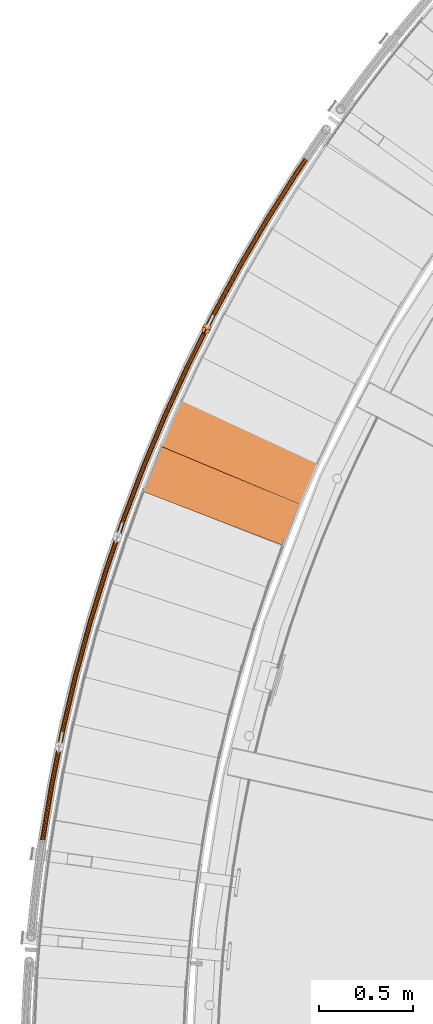
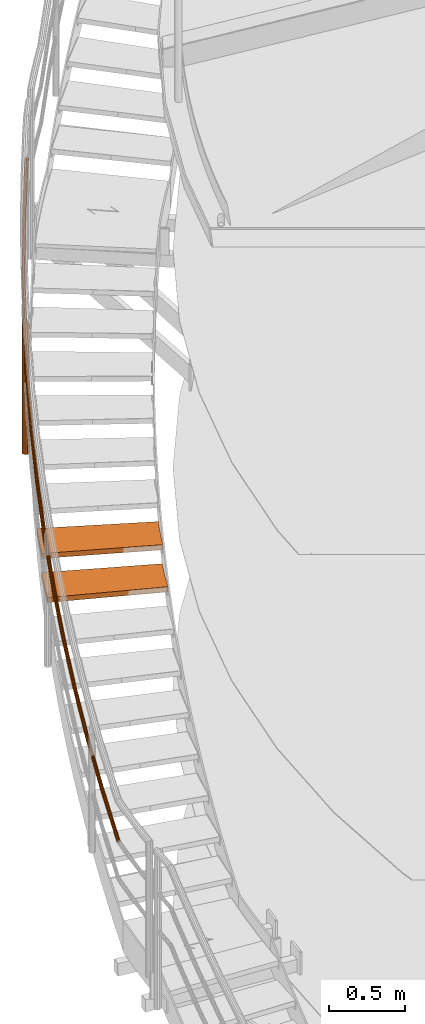
# One storey, part 28 of 126: 4 proxies.
"""IFC2X3 building model written with IfcOpenShell, lengths in millimetres."""

from ifc_helpers import new_model, si_unit, origin, origin_with_axes, place, context, project, spatial, faceted_brep, material, element, save


model = new_model("IFC2X3")

# Units and contexts
context_of_model_1 = context(None, 3, precision=0.1, world=origin())
context_of_model_2 = context(None, 3, precision=0.1, world=origin())
ifc_project = project(units=[si_unit("LENGTHUNIT", "METRE", prefix="MILLI"), si_unit("AREAUNIT", "SQUARE_METRE", prefix="CENTI"), si_unit("VOLUMEUNIT", "CUBIC_METRE", prefix="CENTI"), si_unit("MASSUNIT", "GRAM", prefix="KILO")], contexts=[context_of_model_1, context_of_model_2])

# Site, building, storey
site_placement = place(None, origin_with_axes())
site = spatial("IfcSite", under=ifc_project, at=site_placement, CompositionType="ELEMENT")
building_placement = place(site_placement, origin_with_axes())
building = spatial("IfcBuilding", under=site, at=building_placement, CompositionType="ELEMENT")
storey_placement = place(building_placement, origin_with_axes())
storey = spatial("IfcBuildingStorey", under=building, at=storey_placement, CompositionType="ELEMENT")

# Proxies
ifc_material_1 = material(Name="HOLZ")
proxy_1_placement = place(storey_placement, origin_with_axes())
element("IfcBuildingElementProxy", 1, at=proxy_1_placement, inside=storey, material=ifc_material_1, context=context_of_model_2, shape_type="Brep", body=[
    faceted_brep([(-118.3922, 11432.825, 6928.25), (-128.5897, 11408.558, 6928.25), (-138.7147, 11384.26, 6928.25), (-148.7672, 11359.932, 6928.25), (-158.7469, 11335.574, 6928.25), (-168.6539, 11311.186, 6928.25), (-178.4881, 11286.769, 6928.25), (-188.2493, 11262.323, 6928.25), (-197.9374, 11237.848, 6928.25), (-207.5525, 11213.344, 6928.25), (-217.0944, 11188.811, 6928.25), (-226.5629, 11164.25, 6928.25), (520.3181, 10877.599, 6928.25), (529.8906, 10902.417, 6928.25), (539.5453, 10927.204, 6928.25), (549.2822, 10951.958, 6928.25), (559.1012, 10976.679, 6928.25), (569.0022, 11001.368, 6928.25), (578.985, 11026.025, 6928.25), (589.0496, 11050.647, 6928.25), (599.1959, 11075.237, 6928.25), (609.4236, 11099.792, 6928.25), (619.7328, 11124.313, 6928.25), (-118.3922, 11432.825, 6888.25), (619.7328, 11124.313, 6888.25), (609.4236, 11099.792, 6888.25), (599.1959, 11075.237, 6888.25), (589.0496, 11050.647, 6888.25), (578.985, 11026.025, 6888.25), (569.0022, 11001.368, 6888.25), (559.1012, 10976.679, 6888.25), (549.2822, 10951.958, 6888.25), (539.5453, 10927.204, 6888.25), (529.8906, 10902.417, 6888.25), (520.3181, 10877.599, 6888.25), (-226.5629, 11164.25, 6888.25), (-217.0944, 11188.811, 6888.25), (-207.5525, 11213.344, 6888.25), (-197.9374, 11237.848, 6888.25), (-188.2493, 11262.323, 6888.25), (-178.4881, 11286.769, 6888.25), (-168.6539, 11311.186, 6888.25), (-158.7469, 11335.574, 6888.25), (-148.7672, 11359.932, 6888.25), (-138.7147, 11384.26, 6888.25), (-128.5897, 11408.558, 6888.25)], [[[0, 1, 2, 3, 4, 5, 6, 7, 8, 9, 10, 11, 12, 13, 14, 15, 16, 17, 18, 19, 20, 21, 22]], [[23, 24, 25, 26, 27, 28, 29, 30, 31, 32, 33, 34, 35, 36, 37, 38, 39, 40, 41, 42, 43, 44, 45]], [[0, 23, 45, 1]], [[1, 45, 44, 2]], [[2, 44, 43, 3]], [[3, 43, 42, 4]], [[4, 42, 41, 5]], [[5, 41, 40, 6]], [[6, 40, 39, 7]], [[7, 39, 38, 8]], [[8, 38, 37, 9]], [[9, 37, 36, 10]], [[10, 36, 35, 11]], [[11, 35, 34, 12]], [[12, 34, 33, 13]], [[13, 33, 32, 14]], [[14, 32, 31, 15]], [[15, 31, 30, 16]], [[16, 30, 29, 17]], [[17, 29, 28, 18]], [[18, 28, 27, 19]], [[19, 27, 26, 20]], [[20, 26, 25, 21]], [[21, 25, 24, 22]], [[22, 24, 23, 0]]]),
])
proxy_2_placement = place(storey_placement, origin_with_axes())
element("IfcBuildingElementProxy", 2, at=proxy_2_placement, inside=storey, material=ifc_material_1, context=context_of_model_2, shape_type="Brep", body=[
    faceted_brep([(-13.9794, 11670.441, 7101.4563), (-24.8868, 11646.484, 7101.4563), (-35.7226, 11622.495, 7101.4563), (-46.4867, 11598.473, 7101.4563), (-57.1791, 11574.419, 7101.4563), (-67.7996, 11550.334, 7101.4563), (-78.3482, 11526.217, 7101.4563), (-88.8247, 11502.069, 7101.4563), (-99.2291, 11477.889, 7101.4563), (-109.5612, 11453.679, 7101.4563), (-119.821, 11429.437, 7101.4563), (-130.0084, 11405.165, 7101.4563), (608.1119, 11096.656, 7101.4563), (618.4107, 11121.181, 7101.4563), (628.7908, 11145.673, 7101.4563), (639.2521, 11170.129, 7101.4563), (649.7945, 11194.552, 7101.4563), (660.4179, 11218.939, 7101.4563), (671.1221, 11243.29, 7101.4563), (681.9071, 11267.606, 7101.4563), (692.7726, 11291.886, 7101.4563), (703.7187, 11316.13, 7101.4563), (714.7452, 11340.337, 7101.4563), (-13.9794, 11670.441, 7061.4563), (714.7452, 11340.337, 7061.4563), (703.7187, 11316.13, 7061.4563), (692.7726, 11291.886, 7061.4563), (681.9071, 11267.606, 7061.4563), (671.1221, 11243.29, 7061.4563), (660.4179, 11218.939, 7061.4563), (649.7945, 11194.552, 7061.4563), (639.2521, 11170.129, 7061.4563), (628.7908, 11145.673, 7061.4563), (618.4107, 11121.181, 7061.4563), (608.1119, 11096.656, 7061.4563), (-130.0084, 11405.165, 7061.4563), (-119.821, 11429.437, 7061.4563), (-109.5612, 11453.679, 7061.4563), (-99.2291, 11477.889, 7061.4563), (-88.8247, 11502.069, 7061.4563), (-78.3482, 11526.217, 7061.4563), (-67.7996, 11550.334, 7061.4563), (-57.1791, 11574.419, 7061.4563), (-46.4867, 11598.473, 7061.4563), (-35.7226, 11622.495, 7061.4563), (-24.8868, 11646.484, 7061.4563)], [[[0, 1, 2, 3, 4, 5, 6, 7, 8, 9, 10, 11, 12, 13, 14, 15, 16, 17, 18, 19, 20, 21, 22]], [[23, 24, 25, 26, 27, 28, 29, 30, 31, 32, 33, 34, 35, 36, 37, 38, 39, 40, 41, 42, 43, 44, 45]], [[0, 23, 45, 1]], [[1, 45, 44, 2]], [[2, 44, 43, 3]], [[3, 43, 42, 4]], [[4, 42, 41, 5]], [[5, 41, 40, 6]], [[6, 40, 39, 7]], [[7, 39, 38, 8]], [[8, 38, 37, 9]], [[9, 37, 36, 10]], [[10, 36, 35, 11]], [[11, 35, 34, 12]], [[12, 34, 33, 13]], [[13, 33, 32, 14]], [[14, 32, 31, 15]], [[15, 31, 30, 16]], [[16, 30, 29, 17]], [[17, 29, 28, 18]], [[18, 28, 27, 19]], [[19, 27, 26, 20]], [[20, 26, 25, 21]], [[21, 25, 24, 22]], [[22, 24, 23, 0]]]),
])
ifc_material_2 = material(Name="S235JRG2")
proxy_3_placement = place(storey_placement, origin_with_axes())
element("IfcBuildingElementProxy", 3, at=proxy_3_placement, inside=storey, material=ifc_material_2, context=context_of_model_2, shape_type="Brep", body=[
    faceted_brep([(-762.4523, 9308.8607, 6318.9317), (-768.9726, 9310.8484, 6317.5115), (-770.9614, 9295.8563, 6306.8524), (-764.3214, 9294.7711, 6308.9142), (-773.4726, 9314.362, 6313.5264), (-775.6719, 9297.7832, 6301.7392), (-774.7467, 9318.4601, 6308.0441), (-777.1909, 9300.0356, 6294.9446), (-772.4534, 9322.0447, 6302.5336), (-775.1113, 9302.0098, 6288.2892), (-767.2073, 9324.1551, 6298.4715), (-769.9902, 9303.1769, 6283.5564), (-760.414, 9324.226, 6296.9461), (-763.2001, 9303.2242, 6282.0143), (-753.8938, 9322.2383, 6298.3662), (-756.5601, 9302.139, 6284.076), (-749.3937, 9318.7246, 6302.3513), (-751.8496, 9300.2121, 6289.1893), (-748.1196, 9314.6265, 6307.8336), (-750.3306, 9297.9598, 6295.9839), (-750.4129, 9311.042, 6313.3441), (-752.4103, 9295.9855, 6302.6392), (-755.659, 9308.9316, 6317.4063), (-757.5313, 9294.8184, 6307.372), (-762.3008, 9310.0031, 6317.297), (-756.5176, 9310.0634, 6315.9985), (-758.4576, 9295.4398, 6305.6014), (-764.2381, 9295.3996, 6306.9142), (-752.0516, 9311.8601, 6312.5404), (-754.0981, 9296.4334, 6301.5723), (-750.0993, 9314.9115, 6307.8493), (-752.3277, 9298.1141, 6295.9066), (-751.184, 9318.4003, 6303.1822), (-753.6207, 9300.0315, 6290.1223), (-755.0149, 9321.3914, 6299.7897), (-757.6308, 9301.6719, 6285.7695), (-760.5655, 9323.0836, 6298.5807), (-763.2834, 9302.5958, 6284.0143), (-766.3487, 9323.0232, 6299.8793), (-769.0639, 9302.5555, 6285.3271), (-770.8147, 9321.2266, 6303.3374), (-773.4234, 9301.5619, 6289.3561), (-772.767, 9318.1751, 6308.0285), (-775.1938, 9299.8812, 6295.0219), (-771.6824, 9314.6864, 6312.6956), (-773.9008, 9297.9638, 6300.8061), (-767.8515, 9311.6952, 6316.0881), (-769.8907, 9296.3234, 6305.159), (-714.2788, 9599.5063, 6526.5784), (-720.7294, 9601.7096, 6525.1583), (-725.1102, 9605.3709, 6521.1731), (-726.2473, 9609.5091, 6515.6908), (-723.8362, 9613.0154, 6510.1803), (-718.5228, 9614.9503, 6506.1182), (-711.7309, 9614.7953, 6504.5928), (-705.2804, 9612.5921, 6506.0129), (-700.8996, 9608.9309, 6509.998), (-699.7623, 9604.7927, 6515.4803), (-702.1734, 9601.2863, 6520.9908), (-707.4868, 9599.3514, 6525.053), (-714.0893, 9600.643, 6524.9438), (-708.3073, 9600.5112, 6523.6452), (-703.784, 9602.1584, 6520.187), (-701.7315, 9605.1433, 6515.4959), (-702.6996, 9608.6662, 6510.8289), (-706.429, 9611.783, 6507.4364), (-711.9203, 9613.6586, 6506.2275), (-717.7023, 9613.7905, 6507.526), (-722.2256, 9612.1433, 6510.9841), (-724.2782, 9609.1584, 6515.6752), (-723.3101, 9605.6356, 6520.3423), (-719.5807, 9602.5187, 6523.7348), (-656.4729, 9888.3904, 6734.2251), (-662.8467, 9890.8069, 6732.805), (-667.1034, 9894.6117, 6728.8198), (-668.1024, 9898.7854, 6723.3375), (-665.576, 9902.2097, 6717.8271), (-660.2013, 9903.9669, 6713.7649), (-653.4183, 9903.5863, 6712.2396), (-647.0446, 9901.1699, 6713.6597), (-642.7879, 9897.3652, 6717.6447), (-641.7888, 9893.1915, 6723.127), (-644.315, 9889.7672, 6728.6375), (-649.6898, 9888.0099, 6732.6997), (-656.2458, 9889.5202, 6732.5905), (-650.4713, 9889.1963, 6731.292), (-645.8958, 9890.6923, 6727.8338), (-643.7452, 9893.6074, 6723.1427), (-644.5957, 9897.1604, 6718.4756), (-648.2195, 9900.3994, 6715.0831), (-653.6454, 9902.4565, 6713.8742), (-659.4198, 9902.7805, 6715.1727), (-663.9953, 9901.2846, 6718.6308), (-666.146, 9898.3695, 6723.3219), (-665.2956, 9894.8164, 6727.989), (-661.6718, 9891.5774, 6731.3816), (-589.0985, 10175.194, 6941.8719), (-595.3886, 10177.821, 6940.4517), (-599.5165, 10181.765, 6936.4666), (-600.3762, 10185.97, 6930.9843), (-597.7374, 10189.308, 6925.4738), (-592.3073, 10190.886, 6921.4117), (-585.5407, 10190.28, 6919.8863), (-579.2508, 10187.653, 6921.3064), (-575.1229, 10183.709, 6925.2915), (-574.263, 10179.504, 6930.7738), (-576.9017, 10176.166, 6936.2843), (-582.3318, 10174.588, 6940.3465), (-588.834, 10176.316, 6940.2373), (-583.0735, 10175.8, 6938.9387), (-578.4508, 10177.143, 6935.4805), (-576.2045, 10179.985, 6930.7894), (-576.9365, 10183.564, 6926.1224), (-580.4506, 10186.922, 6922.7299), (-585.8052, 10189.158, 6921.521), (-591.5656, 10189.674, 6922.8195), (-596.1883, 10188.331, 6926.2776), (-598.4347, 10185.489, 6930.9686), (-597.7028, 10181.91, 6935.6357), (-594.1887, 10178.552, 6939.0283), (-512.2302, 10459.6, 7149.5186), (-518.4294, 10462.434, 7148.0985), (-522.424, 10466.514, 7144.1133), (-523.1435, 10470.745, 7138.631), (-520.3952, 10473.993, 7133.1206), (-514.9156, 10475.39, 7129.0584), (-508.1729, 10474.559, 7127.5331), (-501.9738, 10471.725, 7128.9532), (-497.9792, 10467.646, 7132.9382), (-497.2596, 10463.415, 7138.4205), (-500.0077, 10460.166, 7143.931), (-505.4874, 10458.77, 7147.9932), (-511.9285, 10460.712, 7147.884), (-506.1884, 10460.005, 7146.5854), (-501.5236, 10461.194, 7143.1273), (-499.1841, 10463.96, 7138.4362), (-499.7967, 10467.562, 7133.7691), (-503.1973, 10471.034, 7130.3766), (-508.4746, 10473.447, 7129.1677), (-514.2147, 10474.154, 7130.4662), (-518.8795, 10472.965, 7133.9243), (-521.219, 10470.2, 7138.6154), (-520.6065, 10466.598, 7143.2825), (-517.2059, 10463.125, 7146.6751), (-425.9527, 10741.295, 7357.1654), (-432.0543, 10744.333, 7355.7452), (-435.9111, 10748.543, 7351.7601), (-436.4896, 10752.796, 7346.2778), (-433.6349, 10755.951, 7340.7673), (-428.112, 10757.165, 7336.7052), (-421.4006, 10756.111, 7335.1798), (-415.2991, 10753.072, 7336.5999), (-411.4423, 10748.862, 7340.585), (-410.8636, 10744.61, 7346.0672), (-413.7182, 10741.454, 7351.5778), (-419.2412, 10740.241, 7355.64), (-425.6143, 10742.396, 7355.5308), (-419.9008, 10741.499, 7354.2322), (-415.199, 10742.532, 7350.774), (-412.7689, 10745.218, 7346.0829), (-413.2615, 10748.839, 7341.4159), (-416.5448, 10752.422, 7338.0234), (-421.739, 10755.009, 7336.8144), (-427.4524, 10755.906, 7338.113), (-432.1542, 10754.873, 7341.5711), (-434.5844, 10752.187, 7346.2621), (-434.0918, 10748.567, 7350.9292), (-430.8086, 10744.983, 7354.3218), (-330.3614, 11019.966, 7564.8121), (-336.3587, 11023.206, 7563.392), (-340.0734, 11027.542, 7559.4068), (-340.5103, 11031.811, 7553.9245), (-337.5523, 11034.87, 7548.414), (-331.9921, 11035.899, 7544.3519), (-325.3194, 11034.623, 7542.8266), (-319.3223, 11031.383, 7544.2467), (-315.6075, 11027.048, 7548.2317), (-315.1705, 11022.778, 7553.714), (-318.1284, 11019.719, 7559.2245), (-323.6887, 11018.69, 7563.2867), (-329.9866, 11021.056, 7563.1775), (-324.306, 11019.969, 7561.8789), (-319.5726, 11020.845, 7558.4208), (-317.0545, 11023.45, 7553.7297), (-317.4265, 11027.084, 7549.0626), (-320.5889, 11030.775, 7545.6701), (-325.6943, 11033.533, 7544.4612), (-331.3748, 11034.62, 7545.7597), (-336.1082, 11033.744, 7549.2178), (-338.6263, 11031.139, 7553.9089), (-338.2544, 11027.505, 7558.576), (-335.092, 11023.814, 7561.9686), (-225.562, 11295.307, 7772.4589), (-231.4482, 11298.745, 7771.0387), (-235.0169, 11303.201, 7767.0536), (-235.3116, 11307.483, 7761.5713), (-232.2536, 11310.442, 7756.0608), (-226.6622, 11311.286, 7751.9987), (-220.0357, 11309.788, 7750.4733), (-214.1495, 11306.351, 7751.8934), (-210.5809, 11301.894, 7755.8785), (-210.286, 11297.613, 7761.3607), (-213.3439, 11294.654, 7766.8713), (-218.9353, 11293.81, 7770.9335), (-225.1511, 11296.384, 7770.8243), (-219.5098, 11295.109, 7769.5257), (-214.7499, 11295.827, 7766.0675), (-212.1466, 11298.347, 7761.3764), (-212.3977, 11301.991, 7756.7094), (-215.4356, 11305.785, 7753.3169), (-220.4466, 11308.711, 7752.1079), (-226.0878, 11309.986, 7753.4065), (-230.8477, 11309.268, 7756.8646), (-233.451, 11306.749, 7761.5556), (-233.2001, 11303.104, 7766.2227), (-230.1621, 11299.31, 7769.6153), (-111.6701, 11567.013, 7980.1056), (-117.4389, 11570.644, 7978.6855), (-120.8574, 11575.217, 7974.7003), (-121.0097, 11579.506, 7969.218), (-117.8551, 11582.362, 7963.7075), (-112.2387, 11583.02, 7959.6454), (-105.6656, 11581.303, 7958.1201), (-99.8969, 11577.671, 7959.5402), (-96.4783, 11573.099, 7963.5252), (-96.3259, 11568.81, 7969.0075), (-99.4805, 11565.954, 7974.518), (-105.0969, 11565.296, 7978.5802), (-111.2237, 11568.076, 7978.471), (-105.6279, 11566.614, 7977.1724), (-100.8466, 11567.174, 7973.7143), (-98.1611, 11569.605, 7969.0232), (-98.2909, 11573.256, 7964.3561), (-101.2011, 11577.149, 7960.9636), (-106.112, 11580.24, 7959.7547), (-111.7077, 11581.702, 7961.0532), (-116.4889, 11581.142, 7964.5113), (-119.1745, 11578.711, 7969.2024), (-119.0448, 11575.06, 7973.8695), (-116.1346, 11571.167, 7977.262), (11.1884, 11834.784, 8187.7524), (5.5435, 11838.605, 8186.3322), (2.2788, 11843.289, 8182.3471), (2.2691, 11847.581, 8176.8648), (5.5169, 11850.33, 8171.3543), (11.152, 11850.801, 8167.2922), (17.6644, 11848.866, 8165.7668), (23.3093, 11845.045, 8167.1869), (26.574, 11840.362, 8171.172), (26.5838, 11836.07, 8176.6542), (23.3361, 11833.321, 8182.1647), (17.7009, 11832.85, 8186.227), (11.6699, 11835.831, 8186.1178), (17.214, 11834.184, 8184.8192), (22.0112, 11834.585, 8181.361), (24.776, 11836.926, 8176.6699), (24.7677, 11840.579, 8172.0029), (21.9884, 11844.567, 8168.6104), (17.183, 11847.819, 8167.4014), (11.6389, 11849.466, 8168.7), (6.8417, 11849.065, 8172.1581), (4.0769, 11846.725, 8176.8491), (4.0851, 11843.071, 8181.5162), (6.8644, 11839.084, 8184.9088), (142.8778, 12098.324, 8395.3991), (137.3629, 12102.331, 8393.979), (134.2557, 12107.121, 8389.9938), (134.3886, 12111.41, 8384.5115), (137.726, 12114.05, 8379.001), (143.3737, 12114.333, 8374.9389), (149.8182, 12112.183, 8373.4136), (155.3329, 12108.177, 8374.8337), (158.4402, 12103.388, 8378.8187), (158.3074, 12099.098, 8384.301), (154.9701, 12096.458, 8389.8115), (149.3224, 12096.175, 8393.8737), (143.3938, 12099.355, 8393.7645), (148.8801, 12097.525, 8392.4659), (153.688, 12097.766, 8389.0078), (156.529, 12100.013, 8384.3167), (156.6421, 12103.665, 8379.6496), (153.9969, 12107.743, 8376.2571), (149.3022, 12111.153, 8375.0482), (143.8159, 12112.983, 8376.3467), (139.0081, 12112.742, 8379.8048), (136.167, 12110.495, 8384.4959), (136.0538, 12106.843, 8389.163), (138.699, 12102.766, 8392.5555), (283.2525, 12357.343, 8603.0459), (277.8739, 12361.53, 8601.6257), (274.9276, 12366.421, 8597.6406), (275.203, 12370.703, 8592.1582), (278.6263, 12373.231, 8586.6478), (284.2802, 12373.326, 8582.5857), (290.6497, 12370.964, 8581.0603), (296.0283, 12366.776, 8582.4804), (298.9746, 12361.886, 8586.4655), (298.6994, 12357.603, 8591.9477), (295.2761, 12355.075, 8597.4582), (289.6222, 12354.98, 8601.5205), (283.8025, 12358.355, 8601.4113), (289.225, 12356.344, 8600.1127), (294.0382, 12356.425, 8596.6545), (296.9524, 12358.577, 8591.9634), (297.1868, 12362.223, 8587.2964), (294.6785, 12366.386, 8583.9039), (290.0997, 12369.951, 8582.6949), (284.6773, 12371.962, 8583.9935), (279.8641, 12371.881, 8587.4516), (276.9499, 12369.729, 8592.1426), (276.7155, 12366.083, 8596.8097), (279.2237, 12361.92, 8600.2023), (432.1576, 12611.553, 8810.6926), (426.9211, 12615.917, 8809.2725), (424.1389, 12620.903, 8805.2873), (424.5565, 12625.174, 8799.805), (428.0619, 12627.586, 8794.2945), (433.7159, 12627.493, 8790.2324), (440.0034, 12624.92, 8788.7071), (445.2398, 12620.557, 8790.1272), (448.022, 12615.571, 8794.1122), (447.6046, 12611.3, 8799.5945), (444.0992, 12608.887, 8805.105), (438.4452, 12608.98, 8809.1672), (432.7409, 12612.547, 8809.058), (438.0936, 12610.356, 8807.7594), (442.9068, 12610.278, 8804.3013), (445.8909, 12612.331, 8799.6102), (446.2463, 12615.967, 8794.9431), (443.8778, 12620.212, 8791.5506), (439.4201, 12623.927, 8790.3417), (434.0675, 12626.117, 8791.6402), (429.2543, 12626.196, 8795.0983), (426.2701, 12624.142, 8799.7894), (425.9146, 12620.506, 8804.4565), (428.2831, 12616.262, 8807.849), (589.4285, 12860.674, 9018.3394), (584.34, 12865.21, 9016.9192), (581.725, 12870.285, 9012.9341), (582.2843, 12874.54, 9007.4517), (585.8679, 12876.835, 9001.9413), (591.5157, 12876.554, 8997.8792), (597.7142, 12873.774, 8996.3538), (602.8027, 12869.238, 8997.7739), (605.4177, 12864.163, 9001.759), (604.8585, 12859.908, 9007.2412), (601.275, 12857.613, 9012.7517), (595.6272, 12857.894, 9016.814), (590.0446, 12861.648, 9016.7047), (595.3215, 12859.281, 9015.4062), (600.1294, 12859.042, 9011.948), (603.1801, 12860.996, 9007.2569), (603.6562, 12864.618, 9002.5898), (601.43, 12868.939, 8999.1974), (597.0982, 12872.8, 8997.9884), (591.8213, 12875.167, 8999.287), (587.0134, 12875.406, 9002.745), (583.9627, 12873.452, 9007.4361), (583.4865, 12869.83, 9012.1032), (585.7127, 12865.509, 9015.4958), (638.8779, 12933.522, 9080.3956), (633.6673, 12937.86, 9078.7649), (630.455, 12942.007, 9073.968), (630.1007, 12944.851, 9067.2906), (632.699, 12945.632, 9060.5208), (637.5543, 12944.141, 9055.4717), (643.3664, 12940.775, 9053.4959), (648.5784, 12936.437, 9055.1237), (651.7933, 12932.289, 9059.9201), (652.1487, 12929.443, 9066.5999), (649.5489, 12928.662, 9073.3725), (644.6912, 12930.155, 9078.4221), (639.2123, 12934.061, 9078.3956), (644.1611, 12931.195, 9076.7155), (648.2963, 12929.923, 9072.4167), (650.5094, 12930.588, 9066.6514), (650.207, 12933.011, 9060.965), (647.4703, 12936.543, 9056.8818), (643.0333, 12940.235, 9055.4959), (638.0854, 12943.101, 9057.1777), (633.952, 12944.371, 9061.4761), (631.7399, 12943.706, 9067.2393), (632.0416, 12941.284, 9072.924), (634.7764, 12937.754, 9077.0075)], [[[0, 1, 2, 3]], [[1, 4, 5, 2]], [[4, 6, 7, 5]], [[6, 8, 9, 7]], [[8, 10, 11, 9]], [[10, 12, 13, 11]], [[12, 14, 15, 13]], [[14, 16, 17, 15]], [[16, 18, 19, 17]], [[18, 20, 21, 19]], [[20, 22, 23, 21]], [[0, 3, 23, 22]], [[24, 25, 26, 27]], [[25, 28, 29, 26]], [[28, 30, 31, 29]], [[30, 32, 33, 31]], [[32, 34, 35, 33]], [[34, 36, 37, 35]], [[36, 38, 39, 37]], [[38, 40, 41, 39]], [[40, 42, 43, 41]], [[42, 44, 45, 43]], [[44, 46, 47, 45]], [[24, 27, 47, 46]], [[0, 48, 49, 1]], [[1, 49, 50, 4]], [[4, 50, 51, 6]], [[6, 51, 52, 8]], [[8, 52, 53, 10]], [[10, 53, 54, 12]], [[12, 54, 55, 14]], [[14, 55, 56, 16]], [[16, 56, 57, 18]], [[18, 57, 58, 20]], [[20, 58, 59, 22]], [[22, 59, 48, 0]], [[24, 60, 61, 25]], [[25, 61, 62, 28]], [[28, 62, 63, 30]], [[30, 63, 64, 32]], [[32, 64, 65, 34]], [[34, 65, 66, 36]], [[36, 66, 67, 38]], [[38, 67, 68, 40]], [[40, 68, 69, 42]], [[42, 69, 70, 44]], [[44, 70, 71, 46]], [[46, 71, 60, 24]], [[48, 72, 73, 49]], [[49, 73, 74, 50]], [[50, 74, 75, 51]], [[51, 75, 76, 52]], [[52, 76, 77, 53]], [[53, 77, 78, 54]], [[54, 78, 79, 55]], [[55, 79, 80, 56]], [[56, 80, 81, 57]], [[57, 81, 82, 58]], [[58, 82, 83, 59]], [[59, 83, 72, 48]], [[60, 84, 85, 61]], [[61, 85, 86, 62]], [[62, 86, 87, 63]], [[63, 87, 88, 64]], [[64, 88, 89, 65]], [[65, 89, 90, 66]], [[66, 90, 91, 67]], [[67, 91, 92, 68]], [[68, 92, 93, 69]], [[69, 93, 94, 70]], [[70, 94, 95, 71]], [[71, 95, 84, 60]], [[72, 96, 97, 73]], [[73, 97, 98, 74]], [[74, 98, 99, 75]], [[75, 99, 100, 76]], [[76, 100, 101, 77]], [[77, 101, 102, 78]], [[78, 102, 103, 79]], [[79, 103, 104, 80]], [[80, 104, 105, 81]], [[81, 105, 106, 82]], [[82, 106, 107, 83]], [[83, 107, 96, 72]], [[84, 108, 109, 85]], [[85, 109, 110, 86]], [[86, 110, 111, 87]], [[87, 111, 112, 88]], [[88, 112, 113, 89]], [[89, 113, 114, 90]], [[90, 114, 115, 91]], [[91, 115, 116, 92]], [[92, 116, 117, 93]], [[93, 117, 118, 94]], [[94, 118, 119, 95]], [[95, 119, 108, 84]], [[96, 120, 121, 97]], [[97, 121, 122, 98]], [[98, 122, 123, 99]], [[99, 123, 124, 100]], [[100, 124, 125, 101]], [[101, 125, 126, 102]], [[102, 126, 127, 103]], [[103, 127, 128, 104]], [[104, 128, 129, 105]], [[105, 129, 130, 106]], [[106, 130, 131, 107]], [[107, 131, 120, 96]], [[108, 132, 133, 109]], [[109, 133, 134, 110]], [[110, 134, 135, 111]], [[111, 135, 136, 112]], [[112, 136, 137, 113]], [[113, 137, 138, 114]], [[114, 138, 139, 115]], [[115, 139, 140, 116]], [[116, 140, 141, 117]], [[117, 141, 142, 118]], [[118, 142, 143, 119]], [[119, 143, 132, 108]], [[120, 144, 145, 121]], [[121, 145, 146, 122]], [[122, 146, 147, 123]], [[123, 147, 148, 124]], [[124, 148, 149, 125]], [[125, 149, 150, 126]], [[126, 150, 151, 127]], [[127, 151, 152, 128]], [[128, 152, 153, 129]], [[129, 153, 154, 130]], [[130, 154, 155, 131]], [[131, 155, 144, 120]], [[132, 156, 157, 133]], [[133, 157, 158, 134]], [[134, 158, 159, 135]], [[135, 159, 160, 136]], [[136, 160, 161, 137]], [[137, 161, 162, 138]], [[138, 162, 163, 139]], [[139, 163, 164, 140]], [[140, 164, 165, 141]], [[141, 165, 166, 142]], [[142, 166, 167, 143]], [[143, 167, 156, 132]], [[144, 168, 169, 145]], [[145, 169, 170, 146]], [[146, 170, 171, 147]], [[147, 171, 172, 148]], [[148, 172, 173, 149]], [[149, 173, 174, 150]], [[150, 174, 175, 151]], [[151, 175, 176, 152]], [[152, 176, 177, 153]], [[153, 177, 178, 154]], [[154, 178, 179, 155]], [[155, 179, 168, 144]], [[156, 180, 181, 157]], [[157, 181, 182, 158]], [[158, 182, 183, 159]], [[159, 183, 184, 160]], [[160, 184, 185, 161]], [[161, 185, 186, 162]], [[162, 186, 187, 163]], [[163, 187, 188, 164]], [[164, 188, 189, 165]], [[165, 189, 190, 166]], [[166, 190, 191, 167]], [[167, 191, 180, 156]], [[168, 192, 193, 169]], [[169, 193, 194, 170]], [[170, 194, 195, 171]], [[171, 195, 196, 172]], [[172, 196, 197, 173]], [[173, 197, 198, 174]], [[174, 198, 199, 175]], [[175, 199, 200, 176]], [[176, 200, 201, 177]], [[177, 201, 202, 178]], [[178, 202, 203, 179]], [[179, 203, 192, 168]], [[180, 204, 205, 181]], [[181, 205, 206, 182]], [[182, 206, 207, 183]], [[183, 207, 208, 184]], [[184, 208, 209, 185]], [[185, 209, 210, 186]], [[186, 210, 211, 187]], [[187, 211, 212, 188]], [[188, 212, 213, 189]], [[189, 213, 214, 190]], [[190, 214, 215, 191]], [[191, 215, 204, 180]], [[192, 216, 217, 193]], [[193, 217, 218, 194]], [[194, 218, 219, 195]], [[195, 219, 220, 196]], [[196, 220, 221, 197]], [[197, 221, 222, 198]], [[198, 222, 223, 199]], [[199, 223, 224, 200]], [[200, 224, 225, 201]], [[201, 225, 226, 202]], [[202, 226, 227, 203]], [[203, 227, 216, 192]], [[204, 228, 229, 205]], [[205, 229, 230, 206]], [[206, 230, 231, 207]], [[207, 231, 232, 208]], [[208, 232, 233, 209]], [[209, 233, 234, 210]], [[210, 234, 235, 211]], [[211, 235, 236, 212]], [[212, 236, 237, 213]], [[213, 237, 238, 214]], [[214, 238, 239, 215]], [[215, 239, 228, 204]], [[216, 240, 241, 217]], [[217, 241, 242, 218]], [[218, 242, 243, 219]], [[219, 243, 244, 220]], [[220, 244, 245, 221]], [[221, 245, 246, 222]], [[222, 246, 247, 223]], [[223, 247, 248, 224]], [[224, 248, 249, 225]], [[225, 249, 250, 226]], [[226, 250, 251, 227]], [[227, 251, 240, 216]], [[228, 252, 253, 229]], [[229, 253, 254, 230]], [[230, 254, 255, 231]], [[231, 255, 256, 232]], [[232, 256, 257, 233]], [[233, 257, 258, 234]], [[234, 258, 259, 235]], [[235, 259, 260, 236]], [[236, 260, 261, 237]], [[237, 261, 262, 238]], [[238, 262, 263, 239]], [[239, 263, 252, 228]], [[240, 264, 265, 241]], [[241, 265, 266, 242]], [[242, 266, 267, 243]], [[243, 267, 268, 244]], [[244, 268, 269, 245]], [[245, 269, 270, 246]], [[246, 270, 271, 247]], [[247, 271, 272, 248]], [[248, 272, 273, 249]], [[249, 273, 274, 250]], [[250, 274, 275, 251]], [[251, 275, 264, 240]], [[252, 276, 277, 253]], [[253, 277, 278, 254]], [[254, 278, 279, 255]], [[255, 279, 280, 256]], [[256, 280, 281, 257]], [[257, 281, 282, 258]], [[258, 282, 283, 259]], [[259, 283, 284, 260]], [[260, 284, 285, 261]], [[261, 285, 286, 262]], [[262, 286, 287, 263]], [[263, 287, 276, 252]], [[264, 288, 289, 265]], [[265, 289, 290, 266]], [[266, 290, 291, 267]], [[267, 291, 292, 268]], [[268, 292, 293, 269]], [[269, 293, 294, 270]], [[270, 294, 295, 271]], [[271, 295, 296, 272]], [[272, 296, 297, 273]], [[273, 297, 298, 274]], [[274, 298, 299, 275]], [[275, 299, 288, 264]], [[276, 300, 301, 277]], [[277, 301, 302, 278]], [[278, 302, 303, 279]], [[279, 303, 304, 280]], [[280, 304, 305, 281]], [[281, 305, 306, 282]], [[282, 306, 307, 283]], [[283, 307, 308, 284]], [[284, 308, 309, 285]], [[285, 309, 310, 286]], [[286, 310, 311, 287]], [[287, 311, 300, 276]], [[288, 312, 313, 289]], [[289, 313, 314, 290]], [[290, 314, 315, 291]], [[291, 315, 316, 292]], [[292, 316, 317, 293]], [[293, 317, 318, 294]], [[294, 318, 319, 295]], [[295, 319, 320, 296]], [[296, 320, 321, 297]], [[297, 321, 322, 298]], [[298, 322, 323, 299]], [[299, 323, 312, 288]], [[300, 324, 325, 301]], [[301, 325, 326, 302]], [[302, 326, 327, 303]], [[303, 327, 328, 304]], [[304, 328, 329, 305]], [[305, 329, 330, 306]], [[306, 330, 331, 307]], [[307, 331, 332, 308]], [[308, 332, 333, 309]], [[309, 333, 334, 310]], [[310, 334, 335, 311]], [[311, 335, 324, 300]], [[312, 336, 337, 313]], [[313, 337, 338, 314]], [[314, 338, 339, 315]], [[315, 339, 340, 316]], [[316, 340, 341, 317]], [[317, 341, 342, 318]], [[318, 342, 343, 319]], [[319, 343, 344, 320]], [[320, 344, 345, 321]], [[321, 345, 346, 322]], [[322, 346, 347, 323]], [[323, 347, 336, 312]], [[324, 348, 349, 325]], [[325, 349, 350, 326]], [[326, 350, 351, 327]], [[327, 351, 352, 328]], [[328, 352, 353, 329]], [[329, 353, 354, 330]], [[330, 354, 355, 331]], [[331, 355, 356, 332]], [[332, 356, 357, 333]], [[333, 357, 358, 334]], [[334, 358, 359, 335]], [[335, 359, 348, 324]], [[336, 360, 361, 337]], [[337, 361, 362, 338]], [[338, 362, 363, 339]], [[339, 363, 364, 340]], [[340, 364, 365, 341]], [[341, 365, 366, 342]], [[342, 366, 367, 343]], [[343, 367, 368, 344]], [[344, 368, 369, 345]], [[345, 369, 370, 346]], [[346, 370, 371, 347]], [[336, 347, 371, 360]], [[348, 372, 373, 349]], [[349, 373, 374, 350]], [[350, 374, 375, 351]], [[351, 375, 376, 352]], [[352, 376, 377, 353]], [[353, 377, 378, 354]], [[354, 378, 379, 355]], [[355, 379, 380, 356]], [[356, 380, 381, 357]], [[357, 381, 382, 358]], [[358, 382, 383, 359]], [[348, 359, 383, 372]], [[7, 9, 11, 13, 15, 17, 19, 21, 23, 3, 2, 5], [26, 29, 31, 33, 35, 37, 39, 41, 43, 45, 47, 27]], [[360, 371, 370, 369, 368, 367, 366, 365, 364, 363, 362, 361], [372, 383, 382, 381, 380, 379, 378, 377, 376, 375, 374, 373]]]),
])
ifc_material_3 = material(Name="1.4462")
proxy_4_placement = place(storey_placement, origin_with_axes())
element("IfcBuildingElementProxy", 4, at=proxy_4_placement, inside=storey, material=ifc_material_3, Name="Pfosten", context=context_of_model_2, shape_type="Brep", body=[
    faceted_brep([(99.2445, 12011.195, 8473.5708), (89.8965, 12019.495, 8473.5708), (89.8965, 12019.495, 7444.7145), (99.2445, 12011.195, 7444.7136), (85.9508, 12031.357, 8473.5708), (85.9508, 12031.357, 7444.7172), (88.4647, 12043.602, 8473.5708), (88.4647, 12043.602, 7444.7208), (96.7646, 12052.951, 8473.5708), (96.7646, 12052.951, 7444.7244), (108.6265, 12056.896, 8473.5708), (108.6265, 12056.896, 7444.7271), (120.8721, 12054.382, 8473.5708), (120.8721, 12054.382, 7444.7281), (130.2202, 12046.082, 8473.5708), (130.2202, 12046.082, 7444.7271), (134.1658, 12034.22, 8473.5708), (134.1658, 12034.22, 7444.7244), (131.6519, 12021.975, 8473.5708), (131.6519, 12021.975, 7444.7208), (123.352, 12012.627, 8473.5708), (123.352, 12012.627, 7444.7172), (111.4901, 12008.681, 8473.5708), (111.4901, 12008.681, 7444.7145), (131.6702, 12034.072, 8473.5708), (128.133, 12044.706, 8473.5708), (128.133, 12044.706, 7444.7264), (131.6702, 12034.072, 7444.7241), (119.7527, 12052.147, 8473.5708), (119.7527, 12052.147, 7444.7273), (108.7748, 12054.401, 8473.5708), (108.7748, 12054.401, 7444.7264), (98.1408, 12050.863, 8473.5708), (98.1408, 12050.863, 7444.7241), (90.7001, 12042.483, 8473.5708), (90.7001, 12042.483, 7444.7208), (88.4464, 12031.505, 8473.5708), (88.4464, 12031.505, 7444.7176), (91.9836, 12020.871, 8473.5708), (91.9836, 12020.871, 7444.7152), (100.364, 12013.43, 8473.5708), (100.364, 12013.43, 7444.7143), (111.3419, 12011.177, 8473.5708), (111.3419, 12011.177, 7444.7152), (121.9759, 12014.714, 8473.5708), (121.9759, 12014.714, 7444.7176), (129.4166, 12023.094, 8473.5708), (129.4166, 12023.094, 7444.7208), (93.711, 12000.145, 8521.8708), (92.4583, 12001.592, 8521.8708), (92.5951, 12003.5, 8521.8708), (107.823, 12033.908, 8521.8708), (123.0508, 12064.316, 8521.8708), (124.4971, 12065.569, 8521.8708), (126.4056, 12065.432, 8521.8708), (127.6584, 12063.986, 8521.8708), (127.5215, 12062.077, 8521.8708), (112.2937, 12031.669, 8521.8708), (97.0658, 12001.261, 8521.8708), (95.6195, 12000.009, 8521.8708), (125.465, 12063.107, 8521.8708), (125.476, 12063.26, 8521.8708), (125.3757, 12063.375, 8521.8708), (125.2231, 12063.386, 8521.8708), (125.1073, 12063.286, 8521.8708), (109.8795, 12032.878, 8521.8708), (94.6516, 12002.47, 8521.8708), (94.6407, 12002.318, 8521.8708), (94.7409, 12002.202, 8521.8708), (94.8936, 12002.191, 8521.8708), (95.0093, 12002.291, 8521.8708), (110.2372, 12032.699, 8521.8708), (93.711, 12000.145, 8592.916), (92.4583, 12001.592, 8593.4323), (92.5951, 12003.5, 8594.6787), (107.823, 12033.908, 8618.6566), (123.0508, 12064.316, 8642.6345), (124.4971, 12065.569, 8643.8809), (126.4056, 12065.432, 8644.3972), (127.6584, 12063.986, 8643.8809), (127.5215, 12062.077, 8642.6345), (112.2937, 12031.669, 8618.6566), (97.0658, 12001.261, 8594.6787), (95.6195, 12000.009, 8593.4323), (125.465, 12063.107, 8642.6345), (125.476, 12063.26, 8642.7342), (125.3757, 12063.375, 8642.7755), (125.2231, 12063.386, 8642.7342), (125.1073, 12063.286, 8642.6345), (109.8795, 12032.878, 8618.6566), (94.6516, 12002.47, 8594.6787), (94.6407, 12002.318, 8594.579), (94.7409, 12002.202, 8594.5377), (94.8936, 12002.191, 8594.579), (95.0093, 12002.291, 8594.6787), (110.2372, 12032.699, 8618.6566)], [[[0, 1, 2, 3]], [[1, 4, 5, 2]], [[4, 6, 7, 5]], [[6, 8, 9, 7]], [[8, 10, 11, 9]], [[10, 12, 13, 11]], [[12, 14, 15, 13]], [[14, 16, 17, 15]], [[16, 18, 19, 17]], [[18, 20, 21, 19]], [[20, 22, 23, 21]], [[0, 3, 23, 22]], [[24, 25, 26, 27]], [[25, 28, 29, 26]], [[28, 30, 31, 29]], [[30, 32, 33, 31]], [[32, 34, 35, 33]], [[34, 36, 37, 35]], [[36, 38, 39, 37]], [[38, 40, 41, 39]], [[40, 42, 43, 41]], [[42, 44, 45, 43]], [[44, 46, 47, 45]], [[24, 27, 47, 46]], [[0, 48, 49, 1]], [[1, 49, 50, 4]], [[4, 50, 51, 6]], [[6, 51, 52, 8]], [[8, 52, 53, 10]], [[10, 53, 54, 12]], [[12, 54, 55, 14]], [[14, 55, 56, 16]], [[16, 56, 57, 18]], [[18, 57, 58, 20]], [[20, 58, 59, 22]], [[22, 59, 48, 0]], [[24, 60, 61, 25]], [[25, 61, 62, 28]], [[28, 62, 63, 30]], [[30, 63, 64, 32]], [[32, 64, 65, 34]], [[34, 65, 66, 36]], [[36, 66, 67, 38]], [[38, 67, 68, 40]], [[40, 68, 69, 42]], [[42, 69, 70, 44]], [[44, 70, 71, 46]], [[46, 71, 60, 24]], [[48, 72, 73, 49]], [[49, 73, 74, 50]], [[50, 74, 75, 51]], [[51, 75, 76, 52]], [[52, 76, 77, 53]], [[53, 77, 78, 54]], [[54, 78, 79, 55]], [[55, 79, 80, 56]], [[56, 80, 81, 57]], [[57, 81, 82, 58]], [[58, 82, 83, 59]], [[48, 59, 83, 72]], [[60, 84, 85, 61]], [[61, 85, 86, 62]], [[62, 86, 87, 63]], [[63, 87, 88, 64]], [[64, 88, 89, 65]], [[65, 89, 90, 66]], [[66, 90, 91, 67]], [[67, 91, 92, 68]], [[68, 92, 93, 69]], [[69, 93, 94, 70]], [[70, 94, 95, 71]], [[60, 71, 95, 84]], [[7, 9, 11, 13, 15, 17, 19, 21, 23, 3, 2, 5], [26, 29, 31, 33, 35, 37, 39, 41, 43, 45, 47, 27]], [[74, 73, 72, 83, 82, 81, 80, 79, 78, 77, 76, 75], [84, 95, 94, 93, 92, 91, 90, 89, 88, 87, 86, 85]]]),
])

save(model, "model.ifc")
